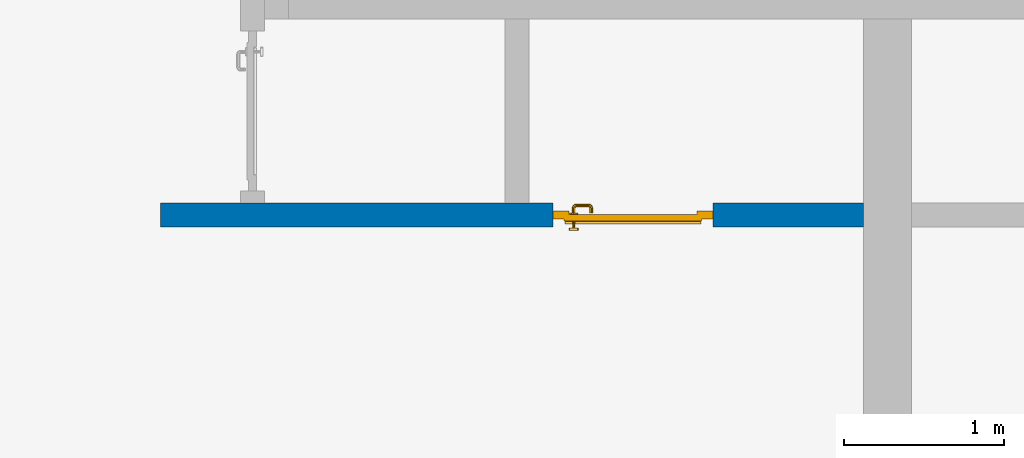
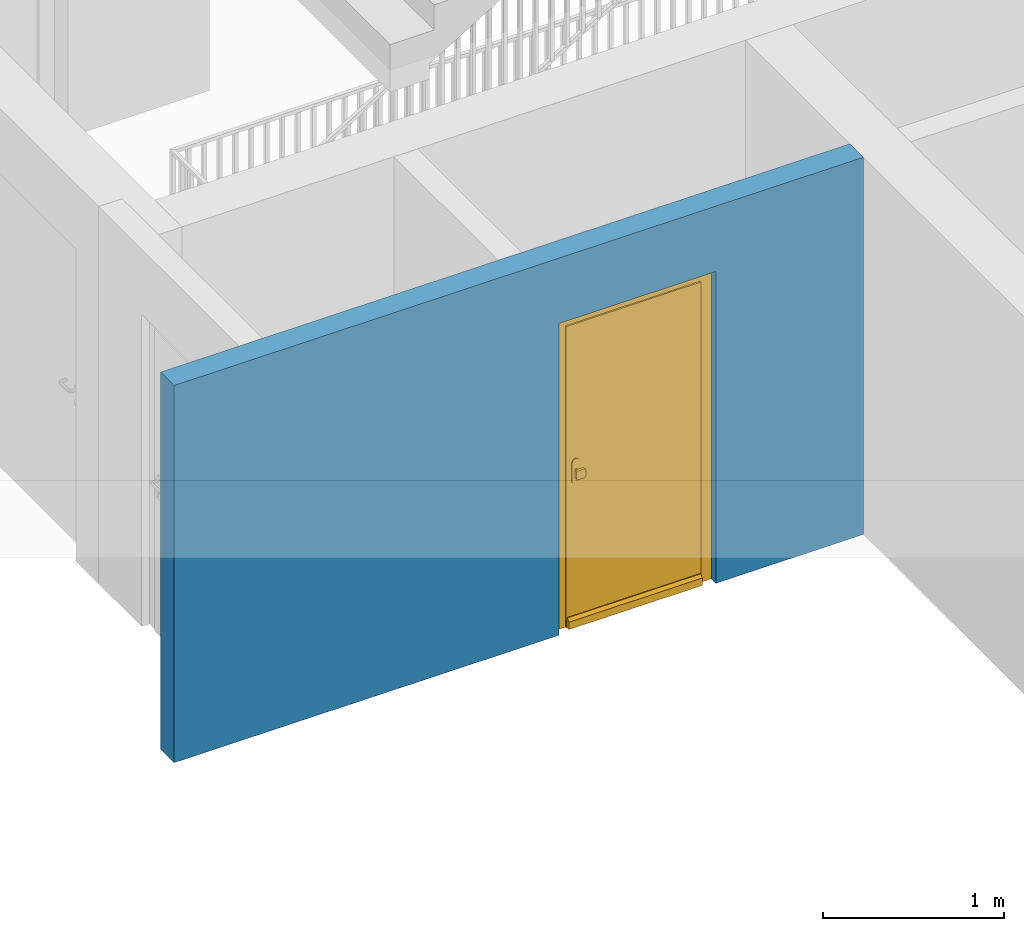
# One storey, part 2 of 48: 1 door, 1 wall, 1 opening.
"""IFC4 building model written with IfcOpenShell, lengths in metres."""

from ifc_helpers import new_model, entity, si_unit, converted_unit, derived_unit, direction, frame, origin_with_axes, place, context, subcontext, project, spatial, polygons, source, transform, mapped, material, type_object, element, fill, save


model = new_model("IFC4")

# Units and contexts
model_context = context("Model", 3, precision=1e-05, world=origin_with_axes(), true_north=direction((0.0, 1.0)))
body_context = subcontext(model_context, "Body", "Model", "MODEL_VIEW")
ifc_project = project(units=[si_unit("LENGTHUNIT", "METRE"), si_unit("AREAUNIT", "SQUARE_METRE"), si_unit("VOLUMEUNIT", "CUBIC_METRE"), converted_unit("PLANEANGLEUNIT", "DEGREE", entity("IfcPlaneAngleMeasure", 0.0174532925199), si_unit("PLANEANGLEUNIT", "RADIAN"), dimensions=[0, 0, 0, 0, 0, 0, 0]), converted_unit("TIMEUNIT", "Year", entity("IfcTimeMeasure", 31556926.0), si_unit("TIMEUNIT", "SECOND"), dimensions=[0, 0, 1, 0, 0, 0, 0]), si_unit("MASSUNIT", "GRAM", prefix="KILO"), si_unit("THERMODYNAMICTEMPERATUREUNIT", "DEGREE_CELSIUS"), si_unit("LUMINOUSINTENSITYUNIT", "LUMEN"), si_unit("ENERGYUNIT", "JOULE", prefix="MEGA"), derived_unit("THERMALCONDUCTANCEUNIT", [(si_unit("POWERUNIT", "WATT"), 1), (si_unit("LENGTHUNIT", "METRE"), -1), (si_unit("THERMODYNAMICTEMPERATUREUNIT", "KELVIN"), -1)]), derived_unit("SPECIFICHEATCAPACITYUNIT", [(si_unit("ENERGYUNIT", "JOULE"), 1), (si_unit("MASSUNIT", "GRAM", prefix="KILO"), -1), (si_unit("THERMODYNAMICTEMPERATUREUNIT", "KELVIN"), -1)]), derived_unit("MASSDENSITYUNIT", [(si_unit("MASSUNIT", "GRAM", prefix="KILO"), 1), (si_unit("VOLUMEUNIT", "CUBIC_METRE"), -1)])], contexts=[model_context])

# Site, building, storey
site_placement = place(None, origin_with_axes())
site = spatial("IfcSite", under=ifc_project, at=site_placement, CompositionType="ELEMENT")
building_placement = place(site_placement, origin_with_axes())
building = spatial("IfcBuilding", under=site, at=building_placement, CompositionType="ELEMENT")
storey_placement = place(building_placement, frame((0.0, 0.0, 3.4), z_axis=(0.0, 0.0, 1.0), x_axis=(1.0, 0.0, 0.0)))
storey = spatial("IfcBuildingStorey", under=building, at=storey_placement, Name="1. Geschoss", CompositionType="ELEMENT", Elevation=3.4)

# Wall, opening, door
ifc_material = material()
wall_type = type_object("IfcWallType", Name="150", PredefinedType="NOTDEFINED")
wall_placement = place(storey_placement, frame((-5.7421993804, -4.12881223104, 0.0), z_axis=(0.0, 0.0, 1.0), x_axis=(1.0, 0.0, 0.0)))
wall = element("IfcWall", 1, at=wall_placement, inside=storey, type_object=wall_type, material=ifc_material, Name="Wand-002", PredefinedType="NOTDEFINED", context=body_context, shape_type="Tessellation", body=[
    polygons([(2.45, 0.15, 2.1), (2.45, 0.15, 0.0), (0.0, 0.15, 0.0), (0.0, 0.15, 2.54), (4.39, 0.15, 2.54), (4.39, 0.15, 0.0), (3.45, 0.15, 0.0), (3.45, 0.15, 2.1), (2.45, 0.05, 0.0), (2.45, 0.0, 2.1), (2.45, 0.0, 0.0), (0.0, 0.0, 0.0), (0.0, 0.0, 2.54), (4.39, 0.0, 2.54), (4.39, 0.0, 0.0), (3.45, 0.05, 0.0), (3.45, 0.0, 0.0), (3.45, 0.0, 2.1)], [[[1, 2, 3, 4, 5, 6, 7, 8]], [[9, 2, 1, 10, 11]], [[2, 9, 11, 12, 3]], [[4, 3, 12, 13]], [[5, 4, 13, 14]], [[14, 15, 6, 5]], [[16, 7, 6, 15, 17]], [[8, 7, 16, 17, 18]], [[1, 8, 18, 10]], [[12, 11, 10, 18, 17, 15, 14, 13]]], closed=True),
])
opening_placement = place(wall_placement, frame((2.95, 0.0, 0.0), z_axis=(0.0, 0.0, 1.0), x_axis=(1.0, 0.0, 0.0)))
opening = element("IfcOpeningElement", 2, at=opening_placement, cuts=wall, context=body_context, identifier="Reference", shape_type="Tessellation", body=[
    polygons([(0.5, 0.05, 0.0), (0.5, 0.05, 2.1), (0.5, -0.001, 2.1), (0.5, -0.001, 0.0), (0.5, 0.151, 0.0), (0.5, 0.151, 2.1), (-0.5, 0.05, 2.1), (-0.5, -0.001, 2.1), (-0.5, 0.151, 2.1), (-0.5, -0.001, 0.0), (-0.5, 0.05, 0.0), (-0.5, 0.151, 0.0)], [[[1, 2, 3, 4]], [[2, 1, 5, 6]], [[7, 8, 3, 2, 6, 9]], [[8, 10, 4, 3]], [[1, 4, 10, 11, 12, 5]], [[6, 5, 12, 9]], [[7, 11, 10, 8]], [[11, 7, 9, 12]]], closed=True),
])
door_type = type_object("IfcDoorType", Name="Eingang 01 1-Fl 26", OperationType="SINGLE_SWING_LEFT", PredefinedType="DOOR")
shared_shape = source(origin_with_axes(), body_context, "Body", "Tessellation", [
    polygons([(-0.5, -0.05, 0.0), (-0.5, -0.05, 2.1), (-0.5, -0.03, 2.1), (-0.5, -0.03, 0.0), (-0.4, -0.05, 0.0), (-0.4, -0.05, 2.0), (-0.1301, -0.05, 2.0), (-0.0001, -0.05, 2.0), (0.4, -0.05, 2.0), (0.4, -0.05, 0.0), (0.5, -0.05, 0.0), (0.5, -0.05, 2.1), (0.5, -0.03, 2.1), (0.5, -0.03, 0.0), (0.4, -0.03, 0.0), (0.4, -0.03, 2.0), (-0.0001, -0.03, 2.0), (-0.1301, -0.03, 2.0), (-0.4, -0.03, 2.0), (-0.4, -0.03, 0.0)], [[[1, 2, 3, 4]], [[1, 5, 6, 7, 8, 9, 10, 11, 12, 2]], [[2, 12, 13, 3]], [[4, 3, 13, 14, 15, 16, 17, 18, 19, 20]], [[5, 1, 4, 20]], [[6, 5, 20, 19]], [[7, 6, 19, 18]], [[8, 7, 18, 17]], [[9, 8, 17, 16]], [[10, 9, 16, 15]], [[11, 10, 15, 14]], [[12, 11, 14, 13]]], closed=True),
    polygons([(-0.5, -0.03, 0.0), (-0.5, -0.03, 2.1), (-0.5, 0.0, 2.1), (-0.5, 0.0, 0.0), (-0.43, -0.03, 0.0), (-0.43, -0.03, 2.03), (-0.1001, -0.03, 2.03), (-0.0301, -0.03, 2.03), (0.43, -0.03, 2.03), (0.43, -0.03, 0.0), (0.5, -0.03, 0.0), (0.5, -0.03, 2.1), (0.5, 0.0, 2.1), (0.5, 0.0, 0.0), (0.43, 0.0, 0.0), (0.43, 0.0, 2.03), (-0.0301, 0.0, 2.03), (-0.1001, 0.0, 2.03), (-0.43, 0.0, 2.03), (-0.43, 0.0, 0.0)], [[[1, 2, 3, 4]], [[1, 5, 6, 7, 8, 9, 10, 11, 12, 2]], [[2, 12, 13, 3]], [[4, 3, 13, 14, 15, 16, 17, 18, 19, 20]], [[5, 1, 4, 20]], [[6, 5, 20, 19]], [[7, 6, 19, 18]], [[8, 7, 18, 17]], [[9, 8, 17, 16]], [[10, 9, 16, 15]], [[11, 10, 15, 14]], [[12, 11, 14, 13]]], closed=True),
    polygons([(-0.43, 0.01, 0.0), (-0.43, 0.01, 2.03), (0.43, 0.01, 2.03), (0.43, 0.01, 0.0), (-0.43, -0.03, 0.0), (-0.43, -0.03, 2.03), (0.43, -0.03, 2.03), (0.43, -0.03, 0.0)], [[[1, 2, 3, 4]], [[1, 5, 6, 2]], [[2, 6, 7, 3]], [[3, 7, 8, 4]], [[4, 8, 5, 1]], [[8, 7, 6, 5]]], closed=True),
    polygons([(-0.425, 0.03, 0.0), (-0.425, 0.03, 0.05), (0.425, 0.03, 0.05), (0.425, 0.03, 0.0), (-0.425, 0.01, 0.0), (-0.425, 0.01, 0.07), (-0.425, 0.015, 0.07), (0.425, 0.015, 0.07), (0.425, 0.01, 0.07), (0.425, 0.01, 0.0)], [[[1, 2, 3, 4]], [[1, 5, 6, 7, 2]], [[2, 7, 8, 3]], [[4, 3, 8, 9, 10]], [[5, 1, 4, 10]], [[6, 5, 10, 9]], [[7, 6, 9, 8]]], closed=True),
    polygons([(0.3835, -0.04, 1.0733826859), (0.3835, -0.0399, 1.0733826859), (0.37, -0.0399, 1.077), (0.37, -0.04, 1.077), (0.393382685902, -0.04, 1.0635), (0.393382685902, -0.0399, 1.0635), (0.3835, -0.0301, 1.0733826859), (0.37, -0.0301, 1.077), (0.3565, -0.0399, 1.0733826859), (0.3565, -0.04, 1.0733826859), (0.346617314098, -0.04, 1.0635), (0.343, -0.04, 1.05), (0.346617314098, -0.04, 1.0365), (0.3565, -0.04, 1.0266173141), (0.37, -0.04, 1.023), (0.3835, -0.04, 1.0266173141), (0.393382685902, -0.04, 1.0365), (0.397, -0.04, 1.05), (0.397, -0.0399, 1.05), (0.393382685902, -0.0301, 1.0635), (0.3835, -0.03, 1.0733826859), (0.37, -0.03, 1.077), (0.3565, -0.0301, 1.0733826859), (0.346617314098, -0.0399, 1.0635), (0.343, -0.0399, 1.05), (0.346617314098, -0.0399, 1.0365), (0.3565, -0.0399, 1.0266173141), (0.37, -0.0399, 1.023), (0.3835, -0.0399, 1.0266173141), (0.393382685902, -0.0399, 1.0365), (0.397, -0.0301, 1.05), (0.393382685902, -0.03, 1.0635), (0.397, -0.03, 1.05), (0.393382685902, -0.03, 1.0365), (0.3835, -0.03, 1.0266173141), (0.37, -0.03, 1.023), (0.3565, -0.03, 1.0266173141), (0.346617314098, -0.03, 1.0365), (0.343, -0.03, 1.05), (0.346617314098, -0.03, 1.0635), (0.3565, -0.03, 1.0733826859), (0.346617314098, -0.0301, 1.0635), (0.343, -0.0301, 1.05), (0.346617314098, -0.0301, 1.0365), (0.3565, -0.0301, 1.0266173141), (0.37, -0.0301, 1.023), (0.3835, -0.0301, 1.0266173141), (0.393382685902, -0.0301, 1.0365)], [[[1, 2, 3, 4]], [[5, 6, 2, 1]], [[2, 7, 8, 3]], [[4, 3, 9, 10]], [[4, 10, 11, 12, 13, 14, 15, 16, 17, 18, 5, 1]], [[18, 19, 6, 5]], [[6, 20, 7, 2]], [[7, 21, 22, 8]], [[3, 8, 23, 9]], [[10, 9, 24, 11]], [[11, 24, 25, 12]], [[12, 25, 26, 13]], [[13, 26, 27, 14]], [[14, 27, 28, 15]], [[15, 28, 29, 16]], [[16, 29, 30, 17]], [[17, 30, 19, 18]], [[19, 31, 20, 6]], [[20, 32, 21, 7]], [[22, 21, 32, 33, 34, 35, 36, 37, 38, 39, 40, 41]], [[8, 22, 41, 23]], [[9, 23, 42, 24]], [[24, 42, 43, 25]], [[25, 43, 44, 26]], [[26, 44, 45, 27]], [[27, 45, 46, 28]], [[28, 46, 47, 29]], [[29, 47, 48, 30]], [[30, 48, 31, 19]], [[31, 33, 32, 20]], [[48, 34, 33, 31]], [[47, 35, 34, 48]], [[46, 36, 35, 47]], [[45, 37, 36, 46]], [[44, 38, 37, 45]], [[43, 39, 38, 44]], [[42, 40, 39, 43]], [[23, 41, 40, 42]]], closed=True),
    polygons([(0.362532169224, -0.04, 0.959692280177), (0.363279754556, -0.04, 0.961639806549), (0.35655, -0.04, 0.973296083362), (0.346703916638, -0.04, 0.96345), (0.365, -0.04, 0.952886751346), (0.365, -0.04, 0.9544), (0.362532169224, -0.039, 0.959692280177), (0.363279754556, -0.039, 0.961639806549), (0.364624817685, -0.039, 0.965143815798), (0.364624817685, -0.04, 0.965143815798), (0.37, -0.04, 0.967425445323), (0.37, -0.04, 0.9769), (0.346617314098, -0.04, 0.9635), (0.3565, -0.04, 0.973382685902), (0.365, -0.04, 0.95), (0.3431, -0.04, 0.95), (0.365, -0.04, 0.947113248654), (0.365, -0.04, 0.941339745962), (0.365, -0.04, 0.9375), (0.365, -0.039, 0.9375), (0.365, -0.039, 0.941339745962), (0.365, -0.039, 0.947113248654), (0.365, -0.039, 0.95), (0.365, -0.039, 0.952886751346), (0.365, -0.039, 0.9544), (0.347569942042, -0.039, 0.96295), (0.35705, -0.039, 0.972430057958), (0.37, -0.039, 0.9759), (0.37, -0.039, 0.967425445323), (0.375375182315, -0.04, 0.965143815798), (0.376720245444, -0.04, 0.961639806549), (0.38345, -0.04, 0.973296083362), (0.37, -0.04, 0.977), (0.343, -0.04, 0.95), (0.346617314098, -0.0399, 0.9635), (0.3565, -0.0399, 0.973382685902), (0.346703916638, -0.04, 0.93655), (0.35655, -0.04, 0.926703916638), (0.37, -0.04, 0.9231), (0.37, -0.04, 0.9325), (0.366464466094, -0.04, 0.933964466094), (0.366464466094, -0.039, 0.933964466094), (0.37, -0.039, 0.9241), (0.35705, -0.039, 0.927569942042), (0.37, -0.039, 0.9325), (0.347569942042, -0.039, 0.93705), (0.3441, -0.039, 0.95), (0.347483339502, -0.039, 0.963), (0.357, -0.039, 0.972516660498), (0.37, -0.039, 0.976), (0.375375182315, -0.039, 0.965143815798), (0.38295, -0.039, 0.972430057958), (0.376720245444, -0.039, 0.961639806549), (0.377467830776, -0.039, 0.959692280177), (0.377467830776, -0.04, 0.959692280177), (0.375, -0.04, 0.9544), (0.375, -0.04, 0.952886751346), (0.393296083362, -0.04, 0.96345), (0.3835, -0.04, 0.973382685902), (0.37, -0.0399, 0.977), (0.346617314098, -0.04, 0.9365), (0.343, -0.0399, 0.95), (0.346617314098, -0.0301, 0.9635), (0.3565, -0.0301, 0.973382685902), (0.3565, -0.04, 0.926617314098), (0.37, -0.04, 0.923), (0.38345, -0.04, 0.926703916638), (0.375, -0.04, 0.941339745962), (0.375, -0.04, 0.9375), (0.373535533906, -0.04, 0.933964466094), (0.37, -0.039, 0.924), (0.357, -0.039, 0.927483339502), (0.38295, -0.039, 0.927569942042), (0.373535533906, -0.039, 0.933964466094), (0.375, -0.039, 0.9375), (0.375, -0.039, 0.941339745962), (0.347483339502, -0.039, 0.937), (0.344, -0.039, 0.95), (0.347483339502, -0.0389, 0.963), (0.357, -0.0389, 0.972516660498), (0.37, -0.0389, 0.976), (0.383, -0.039, 0.972516660498), (0.392430057958, -0.039, 0.96295), (0.375, -0.039, 0.952886751346), (0.375, -0.039, 0.9544), (0.375, -0.039, 0.95), (0.375, -0.039, 0.947113248654), (0.375, -0.04, 0.947113248654), (0.375, -0.04, 0.95), (0.3969, -0.04, 0.95), (0.393382685902, -0.04, 0.9635), (0.3835, -0.0399, 0.973382685902), (0.37, -0.0301, 0.977), (0.346617314098, -0.0399, 0.9365), (0.343, -0.0301, 0.95), (0.346617314098, -0.03, 0.9635), (0.3565, -0.03, 0.973382685902), (0.3565, -0.0399, 0.926617314098), (0.3835, -0.04, 0.926617314098), (0.37, -0.0399, 0.923), (0.393296083362, -0.04, 0.93655), (0.383, -0.039, 0.927483339502), (0.37, -0.0389, 0.924), (0.357, -0.0389, 0.927483339502), (0.392430057958, -0.039, 0.93705), (0.347483339502, -0.0389, 0.937), (0.344, -0.0389, 0.95), (0.347483339502, -0.0301, 0.963), (0.357, -0.0301, 0.972516660498), (0.37, -0.0301, 0.976), (0.383, -0.0389, 0.972516660498), (0.392516660498, -0.039, 0.963), (0.3959, -0.039, 0.95), (0.397, -0.04, 0.95), (0.393382685902, -0.0399, 0.9635), (0.3835, -0.0301, 0.973382685902), (0.37, -0.03, 0.977), (0.346617314098, -0.0301, 0.9365), (0.343, -0.03, 0.95), (0.346703916638, -0.03, 0.96345), (0.35655, -0.03, 0.973296083362), (0.3565, -0.0301, 0.926617314098), (0.393382685902, -0.04, 0.9365), (0.3835, -0.0399, 0.926617314098), (0.37, -0.0301, 0.923), (0.392516660498, -0.039, 0.937), (0.383, -0.0389, 0.927483339502), (0.37, -0.0301, 0.924), (0.357, -0.0301, 0.927483339502), (0.347483339502, -0.0301, 0.937), (0.344, -0.0301, 0.95), (0.347483339502, -0.03, 0.963), (0.357, -0.03, 0.972516660498), (0.37, -0.03, 0.976), (0.383, -0.0301, 0.972516660498), (0.392516660498, -0.0389, 0.963), (0.396, -0.039, 0.95), (0.397, -0.0399, 0.95), (0.393382685902, -0.0301, 0.9635), (0.3835, -0.03, 0.973382685902), (0.37, -0.03, 0.9769), (0.346617314098, -0.03, 0.9365), (0.3431, -0.03, 0.95), (0.347396736961, -0.03, 0.96305), (0.35695, -0.03, 0.972603263039), (0.3565, -0.03, 0.926617314098), (0.393382685902, -0.0399, 0.9365), (0.3835, -0.0301, 0.926617314098), (0.37, -0.03, 0.923), (0.392516660498, -0.0389, 0.937), (0.383, -0.0301, 0.927483339502), (0.37, -0.03, 0.924), (0.357, -0.03, 0.927483339502), (0.347483339502, -0.03, 0.937), (0.344, -0.03, 0.95), (0.37, -0.03, 0.9761), (0.383, -0.03, 0.972516660498), (0.392516660498, -0.0301, 0.963), (0.396, -0.0389, 0.95), (0.397, -0.0301, 0.95), (0.393382685902, -0.03, 0.9635), (0.38345, -0.03, 0.973296083362), (0.346703916638, -0.03, 0.93655), (0.3439, -0.03, 0.95), (0.35655, -0.03, 0.926703916638), (0.393382685902, -0.0301, 0.9365), (0.3835, -0.03, 0.926617314098), (0.37, -0.03, 0.9231), (0.392516660498, -0.0301, 0.937), (0.383, -0.03, 0.927483339502), (0.37, -0.03, 0.9239), (0.35695, -0.03, 0.927396736961), (0.347396736961, -0.03, 0.93695), (0.38305, -0.03, 0.972603263039), (0.392516660498, -0.03, 0.963), (0.396, -0.0301, 0.95), (0.397, -0.03, 0.95), (0.393296083362, -0.03, 0.96345), (0.393382685902, -0.03, 0.9365), (0.38345, -0.03, 0.926703916638), (0.392516660498, -0.03, 0.937), (0.38305, -0.03, 0.927396736961), (0.392603263039, -0.03, 0.96305), (0.396, -0.03, 0.95), (0.3969, -0.03, 0.95), (0.393296083362, -0.03, 0.93655), (0.392603263039, -0.03, 0.93695), (0.3961, -0.03, 0.95)], [[[1, 2, 3, 4, 5, 6]], [[1, 7, 8, 9, 10, 2]], [[10, 11, 12, 3, 2]], [[13, 4, 3, 14]], [[15, 5, 4, 16]], [[6, 5, 15, 17, 18, 19, 20, 21, 22, 23, 24, 25]], [[6, 25, 7, 1]], [[7, 25, 24, 26, 27, 8]], [[9, 8, 27, 28, 29]], [[10, 9, 29, 11]], [[30, 31, 32, 12, 11]], [[14, 3, 12, 33]], [[34, 16, 4, 13]], [[35, 13, 14, 36]], [[17, 15, 16, 37]], [[18, 17, 37, 38]], [[38, 39, 40, 41, 19, 18]], [[19, 41, 42, 20]], [[43, 44, 21, 20, 42, 45]], [[22, 21, 44, 46]], [[23, 22, 46, 47]], [[24, 23, 47, 26]], [[26, 48, 49, 27]], [[27, 49, 50, 28]], [[51, 29, 28, 52, 53]], [[11, 29, 51, 30]], [[30, 51, 53, 54, 55, 31]], [[55, 56, 57, 58, 32, 31]], [[33, 12, 32, 59]], [[36, 14, 33, 60]], [[61, 37, 16, 34]], [[62, 34, 13, 35]], [[63, 35, 36, 64]], [[65, 38, 37, 61]], [[66, 39, 38, 65]], [[39, 67, 68, 69, 70, 40]], [[41, 40, 45, 42]], [[43, 71, 72, 44]], [[73, 43, 45, 74, 75, 76]], [[44, 72, 77, 46]], [[46, 77, 78, 47]], [[47, 78, 48, 26]], [[48, 79, 80, 49]], [[49, 80, 81, 50]], [[28, 50, 82, 52]], [[54, 53, 52, 83, 84, 85]], [[55, 54, 85, 56]], [[85, 84, 86, 87, 76, 75, 69, 68, 88, 89, 57, 56]], [[57, 89, 90, 58]], [[59, 32, 58, 91]], [[60, 33, 59, 92]], [[64, 36, 60, 93]], [[94, 61, 34, 62]], [[95, 62, 35, 63]], [[96, 63, 64, 97]], [[98, 65, 61, 94]], [[99, 67, 39, 66]], [[100, 66, 65, 98]], [[88, 68, 67, 101]], [[70, 69, 75, 74]], [[40, 70, 74, 45]], [[73, 102, 71, 43]], [[71, 103, 104, 72]], [[76, 87, 105, 73]], [[72, 104, 106, 77]], [[77, 106, 107, 78]], [[78, 107, 79, 48]], [[79, 108, 109, 80]], [[80, 109, 110, 81]], [[50, 81, 111, 82]], [[52, 82, 112, 83]], [[86, 84, 83, 113]], [[87, 86, 113, 105]], [[89, 88, 101, 90]], [[91, 58, 90, 114]], [[92, 59, 91, 115]], [[93, 60, 92, 116]], [[97, 64, 93, 117]], [[118, 94, 62, 95]], [[119, 95, 63, 96]], [[120, 96, 97, 121]], [[122, 98, 94, 118]], [[123, 101, 67, 99]], [[124, 99, 66, 100]], [[125, 100, 98, 122]], [[105, 126, 102, 73]], [[102, 127, 103, 71]], [[103, 128, 129, 104]], [[104, 129, 130, 106]], [[106, 130, 131, 107]], [[107, 131, 108, 79]], [[108, 132, 133, 109]], [[109, 133, 134, 110]], [[81, 110, 135, 111]], [[82, 111, 136, 112]], [[83, 112, 137, 113]], [[113, 137, 126, 105]], [[114, 90, 101, 123]], [[115, 91, 114, 138]], [[116, 92, 115, 139]], [[117, 93, 116, 140]], [[121, 97, 117, 141]], [[142, 118, 95, 119]], [[143, 119, 96, 120]], [[144, 120, 121, 145]], [[146, 122, 118, 142]], [[147, 123, 99, 124]], [[148, 124, 100, 125]], [[149, 125, 122, 146]], [[126, 150, 127, 102]], [[127, 151, 128, 103]], [[128, 152, 153, 129]], [[129, 153, 154, 130]], [[130, 154, 155, 131]], [[131, 155, 132, 108]], [[132, 144, 145, 133]], [[133, 145, 156, 134]], [[110, 134, 157, 135]], [[111, 135, 158, 136]], [[112, 136, 159, 137]], [[137, 159, 150, 126]], [[138, 114, 123, 147]], [[139, 115, 138, 160]], [[140, 116, 139, 161]], [[141, 117, 140, 162]], [[145, 121, 141, 156]], [[163, 142, 119, 143]], [[164, 143, 120, 144]], [[165, 146, 142, 163]], [[166, 147, 124, 148]], [[167, 148, 125, 149]], [[168, 149, 146, 165]], [[150, 169, 151, 127]], [[151, 170, 152, 128]], [[152, 171, 172, 153]], [[153, 172, 173, 154]], [[154, 173, 164, 155]], [[155, 164, 144, 132]], [[134, 156, 174, 157]], [[135, 157, 175, 158]], [[136, 158, 176, 159]], [[159, 176, 169, 150]], [[160, 138, 147, 166]], [[161, 139, 160, 177]], [[162, 140, 161, 178]], [[156, 141, 162, 174]], [[173, 163, 143, 164]], [[172, 165, 163, 173]], [[179, 166, 148, 167]], [[180, 167, 149, 168]], [[171, 168, 165, 172]], [[169, 181, 170, 151]], [[170, 182, 171, 152]], [[157, 174, 183, 175]], [[158, 175, 184, 176]], [[176, 184, 181, 169]], [[177, 160, 166, 179]], [[178, 161, 177, 185]], [[174, 162, 178, 183]], [[186, 179, 167, 180]], [[182, 180, 168, 171]], [[181, 187, 182, 170]], [[175, 183, 188, 184]], [[184, 188, 187, 181]], [[185, 177, 179, 186]], [[183, 178, 185, 188]], [[187, 186, 180, 182]], [[188, 185, 186, 187]]], closed=True),
    polygons([(0.38, -0.04, 1.05), (0.38, -0.0709849140336, 1.05), (0.377071067812, -0.070696439392, 1.04292893219), (0.377071067812, -0.04, 1.04292893219), (0.377071067812, -0.04, 1.05707106781), (0.377071067812, -0.070696439392, 1.05707106781), (0.378277987014, -0.0796420579258, 1.05), (0.375518993221, -0.0784992452783, 1.04292893219), (0.37, -0.07, 1.04), (0.37, -0.04, 1.04), (0.37, -0.04, 1.06), (0.37, -0.07, 1.06), (0.375518993221, -0.0784992452783, 1.05707106781), (0.372816199938, -0.0878161999379, 1.05), (0.370704557509, -0.0857045575088, 1.04292893219), (0.368858192988, -0.0757402514855, 1.04), (0.362928932188, -0.069303560608, 1.04292893219), (0.362928932188, -0.04, 1.04292893219), (0.362928932188, -0.04, 1.05707106781), (0.362928932188, -0.069303560608, 1.05707106781), (0.368858192988, -0.0757402514855, 1.06), (0.370704557509, -0.0857045575088, 1.05707106781), (0.364642057926, -0.0932779870137, 1.05), (0.363499245278, -0.0905189932208, 1.04292893219), (0.365606601718, -0.0806066017178, 1.04), (0.362197392755, -0.0729812576926, 1.04292893219), (0.36, -0.0690150859664, 1.05), (0.36, -0.04, 1.05), (0.362197392755, -0.0729812576926, 1.05707106781), (0.365606601718, -0.0806066017178, 1.06), (0.363499245278, -0.0905189932208, 1.05707106781), (0.355984914034, -0.095, 1.05), (0.355696439392, -0.0920710678119, 1.04292893219), (0.360740251485, -0.0838581929877, 1.04), (0.360508645927, -0.0755086459268, 1.04292893219), (0.359438398962, -0.0718384450452, 1.05), (0.360508645927, -0.0755086459268, 1.05707106781), (0.360740251485, -0.0838581929877, 1.06), (0.355696439392, -0.0920710678119, 1.05707106781), (0.274015085966, -0.095, 1.05), (0.274303560608, -0.0920710678119, 1.04292893219), (0.355, -0.085, 1.04), (0.357981257693, -0.0771973927545, 1.04292893219), (0.358397003498, -0.0733970034977, 1.05), (0.357981257693, -0.0771973927545, 1.05707106781), (0.355, -0.085, 1.06), (0.274303560608, -0.0920710678119, 1.05707106781), (0.265357942074, -0.0932779870137, 1.05), (0.266500754722, -0.0905189932208, 1.04292893219), (0.275, -0.085, 1.04), (0.354303560608, -0.0779289321881, 1.04292893219), (0.356838445045, -0.0744383989617, 1.05), (0.354303560608, -0.0779289321881, 1.05707106781), (0.275, -0.085, 1.06), (0.266500754722, -0.0905189932208, 1.05707106781), (0.257183800062, -0.0878161999379, 1.05), (0.259295442491, -0.0857045575088, 1.04292893219), (0.269259748515, -0.0838581929877, 1.04), (0.275696439392, -0.0779289321881, 1.04292893219), (0.354015085966, -0.075, 1.05), (0.275696439392, -0.0779289321881, 1.05707106781), (0.269259748515, -0.0838581929877, 1.06), (0.259295442491, -0.0857045575088, 1.05707106781), (0.251722012986, -0.0796420579258, 1.05), (0.254481006779, -0.0784992452783, 1.04292893219), (0.264393398282, -0.0806066017178, 1.04), (0.272018742307, -0.0771973927545, 1.04292893219), (0.275984914034, -0.075, 1.05), (0.272018742307, -0.0771973927545, 1.05707106781), (0.264393398282, -0.0806066017178, 1.06), (0.254481006779, -0.0784992452783, 1.05707106781), (0.25, -0.0709849140336, 1.05), (0.252928932188, -0.070696439392, 1.04292893219), (0.261141807012, -0.0757402514855, 1.04), (0.269491354073, -0.0755086459268, 1.04292893219), (0.273161554955, -0.0744383989617, 1.05), (0.269491354073, -0.0755086459268, 1.05707106781), (0.261141807012, -0.0757402514855, 1.06), (0.252928932188, -0.070696439392, 1.05707106781), (0.25, -0.04, 1.05), (0.252928932188, -0.04, 1.04292893219), (0.26, -0.07, 1.04), (0.267802607245, -0.0729812576926, 1.04292893219), (0.271602996502, -0.0733970034977, 1.05), (0.267802607245, -0.0729812576926, 1.05707106781), (0.26, -0.07, 1.06), (0.252928932188, -0.04, 1.05707106781), (0.26, -0.04, 1.06), (0.267071067812, -0.04, 1.05707106781), (0.27, -0.04, 1.05), (0.267071067812, -0.04, 1.04292893219), (0.26, -0.04, 1.04), (0.267071067812, -0.069303560608, 1.04292893219), (0.270561601038, -0.0718384450452, 1.05), (0.267071067812, -0.069303560608, 1.05707106781), (0.27, -0.0690150859664, 1.05)], [[[1, 2, 3, 4]], [[5, 6, 2, 1]], [[2, 7, 8, 3]], [[4, 3, 9, 10]], [[11, 12, 6, 5]], [[6, 13, 7, 2]], [[7, 14, 15, 8]], [[3, 8, 16, 9]], [[10, 9, 17, 18]], [[19, 20, 12, 11]], [[12, 21, 13, 6]], [[13, 22, 14, 7]], [[14, 23, 24, 15]], [[8, 15, 25, 16]], [[9, 16, 26, 17]], [[18, 17, 27, 28]], [[28, 27, 20, 19]], [[20, 29, 21, 12]], [[21, 30, 22, 13]], [[22, 31, 23, 14]], [[23, 32, 33, 24]], [[15, 24, 34, 25]], [[16, 25, 35, 26]], [[17, 26, 36, 27]], [[27, 36, 29, 20]], [[29, 37, 30, 21]], [[30, 38, 31, 22]], [[31, 39, 32, 23]], [[32, 40, 41, 33]], [[24, 33, 42, 34]], [[25, 34, 43, 35]], [[26, 35, 44, 36]], [[36, 44, 37, 29]], [[37, 45, 38, 30]], [[38, 46, 39, 31]], [[39, 47, 40, 32]], [[40, 48, 49, 41]], [[33, 41, 50, 42]], [[34, 42, 51, 43]], [[35, 43, 52, 44]], [[44, 52, 45, 37]], [[45, 53, 46, 38]], [[46, 54, 47, 39]], [[47, 55, 48, 40]], [[48, 56, 57, 49]], [[41, 49, 58, 50]], [[42, 50, 59, 51]], [[43, 51, 60, 52]], [[52, 60, 53, 45]], [[53, 61, 54, 46]], [[54, 62, 55, 47]], [[55, 63, 56, 48]], [[56, 64, 65, 57]], [[49, 57, 66, 58]], [[50, 58, 67, 59]], [[51, 59, 68, 60]], [[60, 68, 61, 53]], [[61, 69, 62, 54]], [[62, 70, 63, 55]], [[63, 71, 64, 56]], [[64, 72, 73, 65]], [[57, 65, 74, 66]], [[58, 66, 75, 67]], [[59, 67, 76, 68]], [[68, 76, 69, 61]], [[69, 77, 70, 62]], [[70, 78, 71, 63]], [[71, 79, 72, 64]], [[72, 80, 81, 73]], [[65, 73, 82, 74]], [[66, 74, 83, 75]], [[67, 75, 84, 76]], [[76, 84, 77, 69]], [[77, 85, 78, 70]], [[78, 86, 79, 71]], [[79, 87, 80, 72]], [[80, 87, 88, 89, 90, 91, 92, 81]], [[73, 81, 92, 82]], [[74, 82, 93, 83]], [[75, 83, 94, 84]], [[84, 94, 85, 77]], [[85, 95, 86, 78]], [[86, 88, 87, 79]], [[95, 89, 88, 86]], [[96, 90, 89, 95]], [[93, 91, 90, 96]], [[82, 92, 91, 93]], [[83, 93, 96, 94]], [[94, 96, 95, 85]]], closed=False),
    polygons([(0.364696699141, 0.015, 1.04469669914), (0.37, 0.015, 1.0425), (0.375303300859, 0.015, 1.04469669914), (0.3775, 0.015, 1.05), (0.375303300859, 0.015, 1.05530330086), (0.37, 0.015, 1.0575), (0.364696699141, 0.015, 1.05530330086), (0.3625, 0.015, 1.05), (0.364696699141, 0.055, 1.04469669914), (0.37, 0.055, 1.0425), (0.375303300859, 0.055, 1.04469669914), (0.3775, 0.055, 1.05), (0.375303300859, 0.055, 1.05530330086), (0.37, 0.055, 1.0575), (0.364696699141, 0.055, 1.05530330086), (0.3625, 0.055, 1.05)], [[[1, 2, 3, 4, 5, 6, 7, 8]], [[2, 1, 9, 10]], [[3, 2, 10, 11]], [[4, 3, 11, 12]], [[5, 4, 12, 13]], [[6, 5, 13, 14]], [[7, 6, 14, 15]], [[8, 7, 15, 16]], [[1, 8, 16, 9]], [[9, 16, 15, 14, 13, 12, 11, 10]]], closed=True),
    polygons([(0.395, 0.01, 0.975), (0.393096988313, 0.01, 0.965432914191), (0.393096988313, 0.015, 0.965432914191), (0.395, 0.015, 0.975), (0.395, 0.01, 1.1), (0.393096988313, 0.01, 1.10956708581), (0.38767766953, 0.01, 1.11767766953), (0.379567085809, 0.01, 1.12309698831), (0.37, 0.01, 1.125), (0.360432914191, 0.01, 1.12309698831), (0.35232233047, 0.01, 1.11767766953), (0.346903011687, 0.01, 1.10956708581), (0.345, 0.01, 1.1), (0.345, 0.01, 0.975), (0.346903011687, 0.01, 0.965432914191), (0.35232233047, 0.01, 0.95732233047), (0.360432914191, 0.01, 0.951903011687), (0.37, 0.01, 0.95), (0.379567085809, 0.01, 0.951903011687), (0.38767766953, 0.01, 0.95732233047), (0.38767766953, 0.015, 0.95732233047), (0.379567085809, 0.015, 0.951903011687), (0.37, 0.015, 0.95), (0.360432914191, 0.015, 0.951903011687), (0.35232233047, 0.015, 0.95732233047), (0.346903011687, 0.015, 0.965432914191), (0.345, 0.015, 0.975), (0.345, 0.015, 1.1), (0.346903011687, 0.015, 1.10956708581), (0.35232233047, 0.015, 1.11767766953), (0.360432914191, 0.015, 1.12309698831), (0.37, 0.015, 1.125), (0.379567085809, 0.015, 1.12309698831), (0.38767766953, 0.015, 1.11767766953), (0.393096988313, 0.015, 1.10956708581), (0.395, 0.015, 1.1)], [[[1, 2, 3, 4]], [[1, 5, 6, 7, 8, 9, 10, 11, 12, 13, 14, 15, 16, 17, 18, 19, 20, 2]], [[2, 20, 21, 3]], [[4, 3, 21, 22, 23, 24, 25, 26, 27, 28, 29, 30, 31, 32, 33, 34, 35, 36]], [[5, 1, 4, 36]], [[6, 5, 36, 35]], [[7, 6, 35, 34]], [[8, 7, 34, 33]], [[9, 8, 33, 32]], [[10, 9, 32, 31]], [[11, 10, 31, 30]], [[12, 11, 30, 29]], [[13, 12, 29, 28]], [[14, 13, 28, 27]], [[15, 14, 27, 26]], [[16, 15, 26, 25]], [[17, 16, 25, 24]], [[18, 17, 24, 23]], [[19, 18, 23, 22]], [[20, 19, 22, 21]]], closed=True),
    polygons([(0.39, 0.055, 1.08), (0.395, 0.055, 1.07866025404), (0.395, 0.07, 1.07866025404), (0.39, 0.07, 1.08), (0.35, 0.055, 1.08), (0.345, 0.055, 1.07866025404), (0.341339745962, 0.055, 1.075), (0.34, 0.055, 1.07), (0.34, 0.055, 1.03), (0.341339745962, 0.055, 1.025), (0.345, 0.055, 1.02133974596), (0.35, 0.055, 1.02), (0.39, 0.055, 1.02), (0.395, 0.055, 1.02133974596), (0.398660254038, 0.055, 1.025), (0.4, 0.055, 1.03), (0.4, 0.055, 1.07), (0.398660254038, 0.055, 1.075), (0.398660254038, 0.07, 1.075), (0.4, 0.07, 1.07), (0.4, 0.07, 1.03), (0.398660254038, 0.07, 1.025), (0.395, 0.07, 1.02133974596), (0.39, 0.07, 1.02), (0.35, 0.07, 1.02), (0.345, 0.07, 1.02133974596), (0.341339745962, 0.07, 1.025), (0.34, 0.07, 1.03), (0.34, 0.07, 1.07), (0.341339745962, 0.07, 1.075), (0.345, 0.07, 1.07866025404), (0.35, 0.07, 1.08)], [[[1, 2, 3, 4]], [[1, 5, 6, 7, 8, 9, 10, 11, 12, 13, 14, 15, 16, 17, 18, 2]], [[2, 18, 19, 3]], [[4, 3, 19, 20, 21, 22, 23, 24, 25, 26, 27, 28, 29, 30, 31, 32]], [[5, 1, 4, 32]], [[6, 5, 32, 31]], [[7, 6, 31, 30]], [[8, 7, 30, 29]], [[9, 8, 29, 28]], [[10, 9, 28, 27]], [[11, 10, 27, 26]], [[12, 11, 26, 25]], [[13, 12, 25, 24]], [[14, 13, 24, 23]], [[15, 14, 23, 22]], [[16, 15, 22, 21]], [[17, 16, 21, 20]], [[18, 17, 20, 19]]], closed=True),
])
door_placement = place(opening_placement, frame((0.4, 0.0, 0.0), z_axis=(0.0, 0.0, 1.0), x_axis=(-1.0, 0.0, 0.0)))
door = element("IfcDoor", 3, at=door_placement, inside=storey, type_object=door_type, OverallHeight=2.1, OverallWidth=1.0, PredefinedType="DOOR", context=body_context, shape_type="MappedRepresentation", body=[
    mapped(shared_shape, transform((0.4, -0.05, 0.0))),
])
fill(opening, door)

save(model, "model.ifc")
